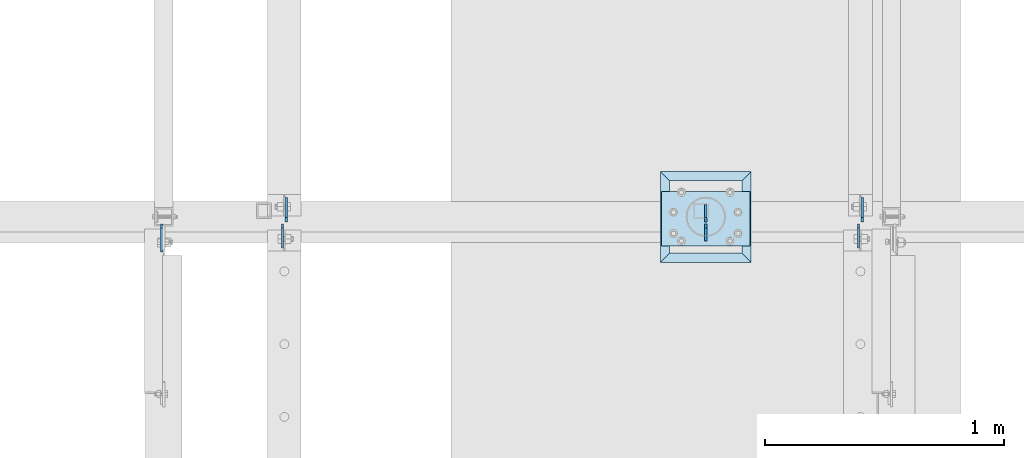
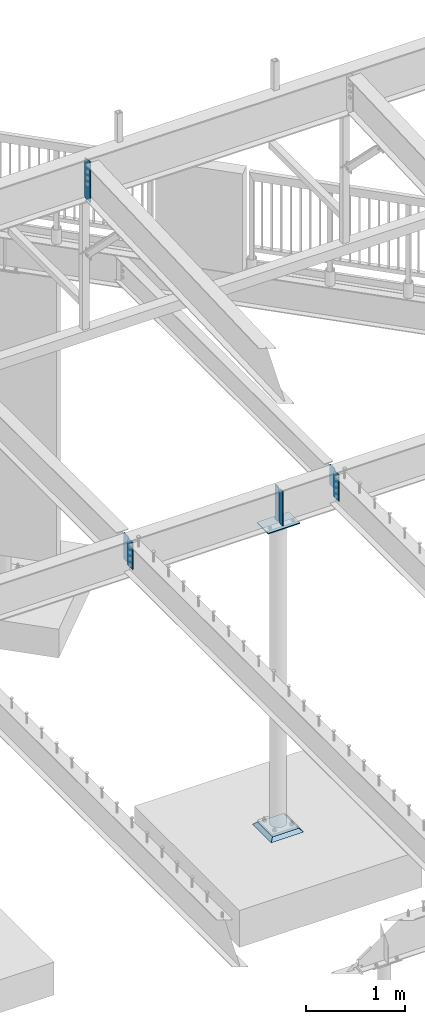
# One storey, part 867 of 975: 9 plates.
"""IFC2X3 building model written with IfcOpenShell, lengths in millimetres."""

from ifc_helpers import new_model, si_unit, frame, origin_with_axes, place, context, subcontext, project, spatial, faceted_brep, material, type_object, element, save


model = new_model("IFC2X3")

# Units and contexts
model_context = context("Model", 3, precision=1e-05, world=origin_with_axes())
body_context = subcontext(model_context, "Body", "Model", "MODEL_VIEW")
ifc_project = project(units=[si_unit("LENGTHUNIT", "METRE", prefix="MILLI"), si_unit("AREAUNIT", "SQUARE_METRE"), si_unit("VOLUMEUNIT", "CUBIC_METRE"), si_unit("MASSUNIT", "GRAM", prefix="KILO"), si_unit("TIMEUNIT", "SECOND"), si_unit("PLANEANGLEUNIT", "RADIAN"), si_unit("SOLIDANGLEUNIT", "STERADIAN"), si_unit("THERMODYNAMICTEMPERATUREUNIT", "DEGREE_CELSIUS"), si_unit("LUMINOUSINTENSITYUNIT", "LUMEN")], contexts=[model_context])

# Site, building, storey
site_placement = place(None, origin_with_axes())
site = spatial("IfcSite", under=ifc_project, at=site_placement, CompositionType="ELEMENT")
building_placement = place(site_placement, origin_with_axes())
building = spatial("IfcBuilding", under=site, at=building_placement, Name="Undefined", CompositionType="ELEMENT")
storey_placement = place(building_placement, origin_with_axes())
storey = spatial("IfcBuildingStorey", under=building, at=storey_placement, Name="Undefined", CompositionType="ELEMENT", Elevation=0.0)

# Plates
ifc_material_1 = material(Name="STEEL/A36")
plate_type_1 = type_object("IfcPlateType", PredefinedType="NOTDEFINED")
plate_1_placement = place(storey_placement, frame((23579.1375, 20625.7038497173, 3670.29999943227), z_axis=(0.0, 0.0, 1.0), x_axis=(0.0, 1.0, 0.0)))
element("IfcPlate", 1, at=plate_1_placement, inside=storey, type_object=plate_type_1, material=ifc_material_1, Name="PLATE", context=body_context, shape_type="Brep", body=[
    faceted_brep([(0.0, -4.76250000000073, 0.0), (0.0, -4.76250000000073, 236.53750038147), (0.0, 4.76250000000073, 236.53750038147), (0.0, 4.76250000000073, 0.0), (17.4624996185303, -4.76250000000073, 254.0), (17.4624996185303, 4.76250000000073, 254.0), (101.600006103516, -4.76250000000073, 254.0), (101.600006103516, 4.76250000000073, 254.0), (101.600006103516, -4.76250000000073, 0.0), (101.600006103516, 4.76250000000073, 0.0)], [[[0, 1, 2, 3]], [[1, 4, 5, 2]], [[4, 6, 7, 5]], [[6, 8, 9, 7]], [[8, 0, 3, 9]], [[5, 7, 9, 3, 2]], [[8, 6, 4, 1, 0]]]),
])
for number, where, z_axis, x_axis, name in (
    (2, (21166.1375, 20625.7038497173, 3594.09999943227), (0.0, 0.0, 1.0), (0.0, 1.0, 0.0), "PLATE"),
    (3, (23563.2625, 20617.7663497173, 3594.09999943227), (0.0, 0.0, 1.0), (0.0, -1.0, 0.0), "PLATE"),
    (4, (21150.2625, 20617.7663497173, 3594.09999943227), (0.0, 0.0, 1.0), (0.0, -1.0, 0.0), "PLATE"),
):
    element("IfcPlate", number, at=place(storey_placement, frame(where, z_axis=z_axis, x_axis=x_axis)), inside=storey, type_object=plate_type_1, material=ifc_material_1, Name=name, context=body_context, shape_type="Brep", body=[
        faceted_brep([(0.0, -4.76250000000073, 0.0), (0.0, -4.76250000000073, 312.737512588501), (0.0, 4.76250000000073, 312.737512588501), (0.0, 4.76250000000073, 0.0), (17.4624996185303, -4.76250000000073, 330.200012207031), (17.4624996185303, 4.76250000000073, 330.200012207031), (101.600006103516, -4.76250000000073, 330.200012207031), (101.600006103516, 4.76250000000073, 330.200012207031), (101.600006103516, -4.76250000000073, 0.0), (101.600006103516, 4.76250000000073, 0.0)], [[[0, 1, 2, 3]], [[1, 4, 5, 2]], [[4, 6, 7, 5]], [[6, 8, 9, 7]], [[8, 0, 3, 9]], [[5, 7, 9, 3, 2]], [[8, 6, 4, 1, 0]]]),
    ])
plate_type_2 = type_object("IfcPlateType", PredefinedType="NOTDEFINED")
plate_2_placement = place(storey_placement, frame((20644.6432500839, 20616.86255, 8323.2625), z_axis=(0.0, 0.0, 1.0), x_axis=(0.0, -1.0, 0.0)))
element("IfcPlate", 5, at=plate_2_placement, inside=storey, type_object=plate_type_2, material=ifc_material_1, Name="PLATE", context=body_context, shape_type="Brep", body=[
    faceted_brep([(0.0, -4.76250000000073, 17.4624996185303), (0.0, -4.76250000000073, 484.187494277954), (0.0, 4.76250000000073, 484.187494277954), (0.0, 4.76250000000073, 17.4624996185303), (17.4624996185303, -4.76250000000073, 501.649993896484), (17.4624996185303, 4.76250000000073, 501.649993896484), (117.111587524414, -4.76250000000073, 501.649993896484), (117.111587524414, 4.76250000000073, 501.649993896484), (117.111587524414, -4.76250000000073, 0.0), (117.111587524414, 4.76250000000073, 0.0), (17.4624996185303, -4.76250000000073, 0.0), (17.4624996185303, 4.76250000000073, 0.0)], [[[0, 1, 2, 3]], [[1, 4, 5, 2]], [[4, 6, 7, 5]], [[6, 8, 9, 7]], [[8, 10, 11, 9]], [[10, 0, 3, 11]], [[5, 7, 9, 11, 3, 2]], [[10, 8, 6, 4, 1, 0]]]),
])
plate_type_3 = type_object("IfcPlateType", PredefinedType="NOTDEFINED")
for number, where, z_axis, x_axis, name in (
    (6, (22923.4995000839, 20625.8805252827, 3495.675), (0.0, 0.0, 1.0), (0.0, 1.0, 0.0), "PLATE"),
    (7, (22923.5, 20617.7663497173, 3495.675), (0.0, 0.0, 1.0), (0.0, -1.0, 0.0), "PLATE"),
):
    element("IfcPlate", number, at=place(storey_placement, frame(where, z_axis=z_axis, x_axis=x_axis)), inside=storey, type_object=plate_type_3, material=ifc_material_1, Name=name, context=body_context, shape_type="Brep", body=[
        faceted_brep([(0.0, -4.76250000000073, 17.4624996185303), (0.0, -4.76250000000073, 411.16250038147), (0.0, 4.76250000000073, 411.16250038147), (0.0, 4.76250000000073, 17.4624996185303), (17.4624996185303, -4.76250000000073, 428.625), (17.4624996185303, 4.76250000000073, 428.625), (72.2312469482422, -4.76250000000073, 428.625), (72.2312469482422, 4.76250000000073, 428.625), (72.2312469482422, -4.76250000000073, 0.0), (72.2312469482422, 4.76250000000073, 0.0), (17.4624996185303, -4.76250000000073, 0.0), (17.4624996185303, 4.76250000000073, 0.0)], [[[0, 1, 2, 3]], [[1, 4, 5, 2]], [[4, 6, 7, 5]], [[6, 8, 9, 7]], [[8, 10, 11, 9]], [[10, 0, 3, 11]], [[5, 7, 9, 11, 3, 2]], [[10, 8, 6, 4, 1, 0]]]),
    ])
plate_type_4 = type_object("IfcPlateType", PredefinedType="NOTDEFINED")
plate_3_placement = place(storey_placement, frame((23109.2375, 20753.3875, 3476.625), z_axis=(-0.999999999999998, 6.90000001668524e-08, 0.0), x_axis=(0.0, -1.0, 0.0)))
element("IfcPlate", 8, at=plate_3_placement, inside=storey, type_object=plate_type_4, material=ifc_material_1, Name="PLATE", context=body_context, shape_type="Brep", body=[
    faceted_brep([(0.0, -6.34999999998763, -3.63797880709171e-12), (0.0, -6.34999999991669, 371.475006103814), (0.0, 6.35000000008222, 371.475006103821), (0.0, 6.34999999999491, 5.45696821063757e-12), (228.600006103516, -6.34999999999991, 371.475006103516), (228.600006103516, 6.34999999999991, 371.475006103516), (228.600006103516, -6.34999999999991, 0.0), (228.600006103516, 6.34999999999991, 0.0)], [[[0, 1, 2, 3]], [[1, 4, 5, 2]], [[4, 6, 7, 5]], [[6, 0, 3, 7]], [[5, 7, 3, 2]], [[6, 4, 1, 0]]]),
])
ifc_material_2 = material(Name="CONCRETE/GROUT")
plate_type_5 = type_object("IfcPlateType", PredefinedType="NOTDEFINED")
plate_4_placement = place(storey_placement, frame((23114.0, 20456.5250000001, -285.749999999999), z_axis=(-0.999999999999998, 6.90000001668524e-08, 0.0), x_axis=(0.0, 1.0, 0.0)))
element("IfcPlate", 9, at=plate_4_placement, inside=storey, type_object=plate_type_5, material=ifc_material_2, Name="GROUT", context=body_context, shape_type="Brep", body=[
    faceted_brep([(38.1000000096292, -19.05, 342.899999985777), (0.0, 19.05, 381.0), (2.63382389675826e-07, 19.0500000000138, 0.0), (38.1000000092372, -19.05, 38.1000000116328), (342.899999988684, -19.05, 38.1000000120257), (381.0, 19.05, 0.0), (381.0, 19.05, 381.0), (342.899999989076, -19.05, 342.89999998617)], [[[0, 1, 2, 3]], [[4, 5, 6, 7]], [[4, 7, 0, 3]], [[5, 4, 3, 2]], [[6, 5, 2, 1]], [[7, 6, 1, 0]]]),
])

save(model, "model.ifc")
